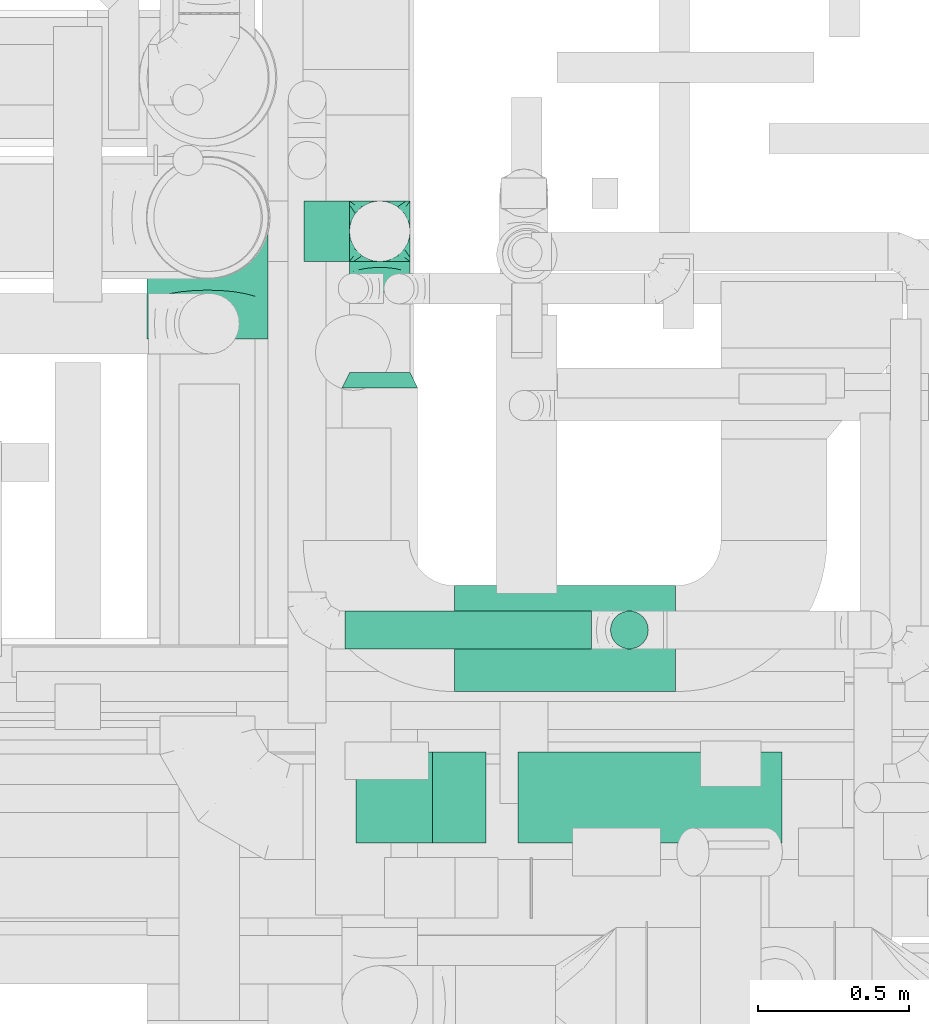
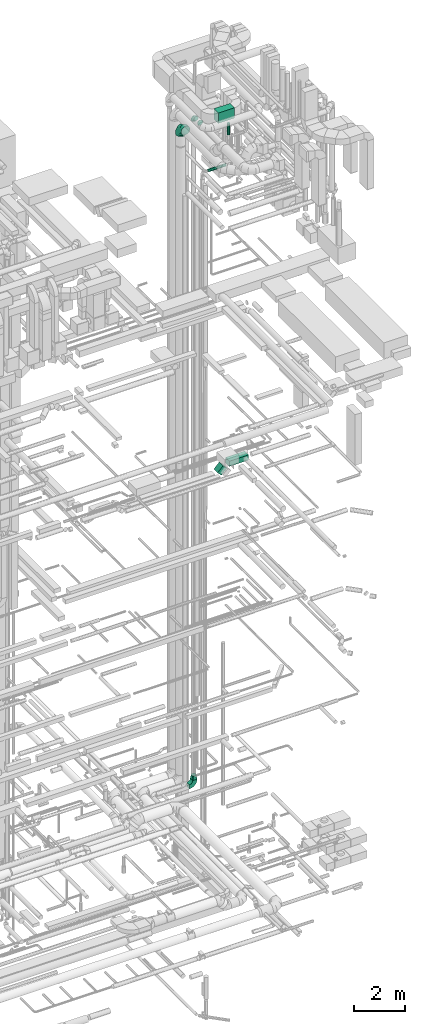
# One storey, part 261 of 337: 5 flow fittings, 5 flow segments.
"""IFC2X3 building model written with IfcOpenShell, lengths in millimetres."""

from ifc_helpers import new_model, entity, si_unit, converted_unit, derived_unit, direction, frame, frame_2d, origin, origin_2d_with_axis, place, context, subcontext, project, spatial, polyline, circle_curve, parameter, trimmed, segment, composite_curve, rectangle, circle, outline, extrude, faceted_brep, source, transform, mapped, material, type_object, type_shapes, element, save


model = new_model("IFC2X3")

# Units and contexts
model_context = context("Model", 3, precision=0.01, world=origin(), true_north=direction((6.12303176911189e-17, 1.0)))
body_context = subcontext(model_context, "Body", "Model", "MODEL_VIEW")
ifc_project = project(units=[si_unit("LENGTHUNIT", "METRE", prefix="MILLI"), si_unit("AREAUNIT", "SQUARE_METRE"), si_unit("VOLUMEUNIT", "CUBIC_METRE"), converted_unit("PLANEANGLEUNIT", "DEGREE", entity("IfcRatioMeasure", 0.0174532925199433), si_unit("PLANEANGLEUNIT", "RADIAN"), dimensions=[0, 0, 0, 0, 0, 0, 0]), si_unit("MASSUNIT", "GRAM", prefix="KILO"), derived_unit("MASSDENSITYUNIT", [(si_unit("MASSUNIT", "GRAM", prefix="KILO"), 1), (si_unit("LENGTHUNIT", "METRE"), -3)]), derived_unit("MOMENTOFINERTIAUNIT", [(si_unit("LENGTHUNIT", "METRE"), 4)]), si_unit("TIMEUNIT", "SECOND"), si_unit("FREQUENCYUNIT", "HERTZ"), si_unit("THERMODYNAMICTEMPERATUREUNIT", "DEGREE_CELSIUS"), derived_unit("THERMALTRANSMITTANCEUNIT", [(si_unit("MASSUNIT", "GRAM", prefix="KILO"), 1), (si_unit("THERMODYNAMICTEMPERATUREUNIT", "KELVIN"), -1), (si_unit("TIMEUNIT", "SECOND"), -3)]), derived_unit("VOLUMETRICFLOWRATEUNIT", [(si_unit("LENGTHUNIT", "METRE"), 3), (si_unit("TIMEUNIT", "SECOND"), -1)]), derived_unit("MASSFLOWRATEUNIT", [(si_unit("MASSUNIT", "GRAM", prefix="KILO"), 1), (si_unit("TIMEUNIT", "SECOND"), -1)]), derived_unit("ROTATIONALFREQUENCYUNIT", [(si_unit("TIMEUNIT", "SECOND"), -1)]), si_unit("ELECTRICCURRENTUNIT", "AMPERE"), si_unit("ELECTRICVOLTAGEUNIT", "VOLT"), si_unit("POWERUNIT", "WATT"), si_unit("FORCEUNIT", "NEWTON", prefix="KILO"), si_unit("ILLUMINANCEUNIT", "LUX"), si_unit("LUMINOUSFLUXUNIT", "LUMEN"), si_unit("LUMINOUSINTENSITYUNIT", "CANDELA"), derived_unit("USERDEFINED", [(si_unit("MASSUNIT", "GRAM", prefix="KILO"), -1), (si_unit("LENGTHUNIT", "METRE"), -2), (si_unit("TIMEUNIT", "SECOND"), 3), (si_unit("LUMINOUSFLUXUNIT", "LUMEN"), 1)]), derived_unit("LINEARVELOCITYUNIT", [(si_unit("LENGTHUNIT", "METRE"), 1), (si_unit("TIMEUNIT", "SECOND"), -1)]), si_unit("PRESSUREUNIT", "PASCAL"), derived_unit("USERDEFINED", [(si_unit("LENGTHUNIT", "METRE"), -2), (si_unit("MASSUNIT", "GRAM", prefix="KILO"), 1), (si_unit("TIMEUNIT", "SECOND"), -2)]), derived_unit("LINEARFORCEUNIT", [(si_unit("MASSUNIT", "GRAM", prefix="KILO"), 1), (si_unit("LENGTHUNIT", "METRE"), 1), (si_unit("TIMEUNIT", "SECOND"), -2), (si_unit("LENGTHUNIT", "METRE"), -1)]), derived_unit("PLANARFORCEUNIT", [(si_unit("MASSUNIT", "GRAM", prefix="KILO"), 1), (si_unit("LENGTHUNIT", "METRE"), 1), (si_unit("TIMEUNIT", "SECOND"), -2), (si_unit("LENGTHUNIT", "METRE"), -2)])], contexts=[model_context])

# Site, building, storey
site_placement = place(None, origin())
site = spatial("IfcSite", under=ifc_project, at=site_placement, CompositionType="ELEMENT")
building_placement = place(site_placement, origin())
building = spatial("IfcBuilding", under=site, at=building_placement, CompositionType="ELEMENT")
storey_placement = place(building_placement, origin())
storey = spatial("IfcBuildingStorey", under=building, at=storey_placement, CompositionType="ELEMENT", Elevation=0.0)

# Flow segments
duct_segment_type_1 = type_object("IfcDuctSegmentType", PredefinedType="NOTDEFINED")
flow_segment_1_placement = place(storey_placement, frame((68048.64, 9724.07, 18727.16)))
element("IfcFlowSegment", 1, at=flow_segment_1_placement, inside=storey, type_object=duct_segment_type_1, context=body_context, shape_type="SweptSolid", body=[
    extrude(rectangle(XDim=249.999999999991, YDim=300.0, at=origin_2d_with_axis()), frame((88.39, 150.0, 88.39), z_axis=(0.707106781186426, 0.0, 0.707106781186669), x_axis=(-0.707106781186669, 0.0, 0.707106781186426)), (0.0, 0.0, 1.0), 359.08116907954),
])
flow_segment_2_placement = place(storey_placement, frame((68585.39, 9724.07, 19025.0)))
element("IfcFlowSegment", 2, at=flow_segment_2_placement, inside=storey, type_object=duct_segment_type_1, context=body_context, shape_type="SweptSolid", body=[
    extrude(rectangle(XDim=871.091270347514, YDim=299.999999999999, at=origin_2d_with_axis()), frame((435.55, 150.0, 0.0), z_axis=(0.0, 0.0, 1.0), x_axis=(-1.0, 0.0, 0.0)), (0.0, 0.0, 1.0), 249.999999999999),
])
flow_segment_3_placement = place(storey_placement, frame((68374.87, 10223.58, 35280.0)))
element("IfcFlowSegment", 3, at=flow_segment_3_placement, inside=storey, type_object=duct_segment_type_1, context=body_context, shape_type="SweptSolid", body=[
    extrude(rectangle(XDim=730.500803225467, YDim=350.000000000001, at=origin_2d_with_axis()), frame((365.25, 175.0, 0.0), z_axis=(0.0, 0.0, 1.0), x_axis=(-1.0, 0.0, 0.0)), (0.0, 0.0, 1.0), 499.999999999999),
])
duct_segment_type_2 = type_object("IfcDuctSegmentType", PredefinedType="NOTDEFINED")
flow_segment_4_placement = place(storey_placement, frame((68888.36, 10363.17, 34432.5)))
element("IfcFlowSegment", 4, at=flow_segment_4_placement, inside=storey, type_object=duct_segment_type_2, context=body_context, shape_type="SweptSolid", body=[
    extrude(circle(Radius=62.5, at=origin_2d_with_axis()), frame((64.1, 64.1, 0.0)), (0.0, 0.0, 1.0), 542.499999999998),
])
flow_segment_5_placement = place(storey_placement, frame((68013.0, 10363.17, 32950.9)))
element("IfcFlowSegment", 5, at=flow_segment_5_placement, inside=storey, type_object=duct_segment_type_2, context=body_context, shape_type="SweptSolid", body=[
    extrude(circle(Radius=62.5, at=origin_2d_with_axis()), frame((0.0, 64.1, 64.1), z_axis=(1.0, 0.0, 0.0), x_axis=(0.0, 1.0, 0.0)), (0.0, 0.0, 1.0), 814.453755383621),
])

# Flow fittings
ifc_material = material()
duct_fitting_type_1 = type_object("IfcDuctFittingType", PredefinedType="NOTDEFINED", material=ifc_material)
shared_shape_1 = source(origin(), body_context, "Body", "Brep", [
    faceted_brep([(-200.0, 0.0, -100.0), (-200.0, -25.88, -96.59), (-200.0, -50.0, -86.6), (-200.0, -70.71, -70.71), (-200.0, -86.6, -50.0), (-200.0, -96.59, -25.88), (-200.0, -100.0, 0.0), (-200.0, -96.59, 25.88), (-200.0, -86.6, 50.0), (-200.0, -70.71, 70.71), (-200.0, -50.0, 86.6), (-200.0, -25.88, 96.59), (-200.0, 0.0, 100.0), (-200.0, 25.88, 96.59), (-200.0, 50.0, 86.6), (-200.0, 70.71, 70.71), (-200.0, 86.6, 50.0), (-200.0, 96.59, 25.88), (-200.0, 100.0, 0.0), (-200.0, 96.59, -25.88), (-200.0, 86.6, -50.0), (-200.0, 70.71, -70.71), (-200.0, 50.0, -86.6), (-200.0, 25.88, -96.59), (-153.35, 25.88, 96.59), (-159.81, 50.0, 86.6), (-146.41, 0.0, 100.0), (-165.36, 70.71, 70.71), (-172.29, 96.59, 25.88), (-173.21, 100.0, 0.0), (-169.62, 86.6, 50.0), (-169.62, 86.6, -50.0), (-165.36, 70.71, -70.71), (-172.29, 96.59, -25.88), (-153.35, 25.88, -96.59), (-146.41, 0.0, -100.0), (-159.81, 50.0, -86.6), (-139.48, -25.88, -96.59), (-133.01, -50.0, -86.6), (-127.46, -70.71, -70.71), (-123.21, -86.6, -50.0), (-120.53, -96.59, -25.88), (-119.62, -100.0, 0.0), (-120.53, -96.59, 25.88), (-123.21, -86.6, 50.0), (-127.46, -70.71, 70.71), (-133.01, -50.0, 86.6), (-139.48, -25.88, 96.59), (-72.54, 72.54, 96.59), (-90.19, 90.19, 86.6), (-53.59, 53.59, 100.0), (-105.35, 105.35, 70.71), (-116.99, 116.99, 50.0), (-124.3, 124.3, 25.88), (-126.79, 126.79, 0.0), (-124.3, 124.3, -25.88), (-116.99, 116.99, -50.0), (-105.35, 105.35, -70.71), (-72.54, 72.54, -96.59), (-53.59, 53.59, -100.0), (-90.19, 90.19, -86.6), (-34.64, 34.64, -96.59), (-16.99, 16.99, -86.6), (-1.83, 1.83, -70.71), (9.81, -9.81, -50.0), (17.12, -17.12, -25.88), (19.62, -19.62, 0.0), (17.12, -17.12, 25.88), (9.81, -9.81, 50.0), (-1.83, 1.83, 70.71), (-16.99, 16.99, 86.6), (-34.64, 34.64, 96.59), (-25.88, 153.35, 96.59), (-50.0, 159.81, 86.6), (0.0, 146.41, 100.0), (-70.71, 165.36, 70.71), (-86.6, 169.62, 50.0), (-96.59, 172.29, 25.88), (-100.0, 173.21, 0.0), (-96.59, 172.29, -25.88), (-86.6, 169.62, -50.0), (-70.71, 165.36, -70.71), (-25.88, 153.35, -96.59), (0.0, 146.41, -100.0), (-50.0, 159.81, -86.6), (25.88, 139.48, -96.59), (50.0, 133.01, -86.6), (70.71, 127.46, -70.71), (86.6, 123.21, -50.0), (96.59, 120.53, -25.88), (100.0, 119.62, 0.0), (96.59, 120.53, 25.88), (86.6, 123.21, 50.0), (70.71, 127.46, 70.71), (50.0, 133.01, 86.6), (25.88, 139.48, 96.59), (-25.88, 200.0, -96.59), (-50.0, 200.0, -86.6), (-70.71, 200.0, -70.71), (-86.6, 200.0, -50.0), (-96.59, 200.0, -25.88), (-100.0, 200.0, 0.0), (-96.59, 200.0, 25.88), (-86.6, 200.0, 50.0), (-70.71, 200.0, 70.71), (-50.0, 200.0, 86.6), (-25.88, 200.0, 96.59), (0.0, 200.0, 100.0), (25.88, 200.0, 96.59), (50.0, 200.0, 86.6), (70.71, 200.0, 70.71), (86.6, 200.0, 50.0), (96.59, 200.0, 25.88), (100.0, 200.0, 0.0), (96.59, 200.0, -25.88), (86.6, 200.0, -50.0), (70.71, 200.0, -70.71), (50.0, 200.0, -86.6), (25.88, 200.0, -96.59), (0.0, 200.0, -100.0)], [[[0, 1, 2, 3, 4, 5, 6, 7, 8, 9, 10, 11, 12, 13, 14, 15, 16, 17, 18, 19, 20, 21, 22, 23]], [[24, 25, 14, 13]], [[26, 24, 13, 12]], [[14, 25, 27, 15]], [[28, 29, 18, 17]], [[30, 28, 17, 16]], [[15, 27, 30, 16]], [[20, 31, 32, 21]], [[33, 31, 20, 19]], [[18, 29, 33, 19]], [[34, 35, 0, 23]], [[36, 34, 23, 22]], [[32, 36, 22, 21]], [[1, 0, 35, 37]], [[2, 1, 37, 38]], [[38, 39, 3, 2]], [[5, 4, 40, 41]], [[6, 5, 41, 42]], [[39, 40, 4, 3]], [[6, 42, 43, 7]], [[7, 43, 44, 8]], [[8, 44, 45, 9]], [[9, 45, 46, 10]], [[10, 46, 47, 11]], [[26, 12, 11, 47]], [[48, 49, 25, 24]], [[50, 48, 24, 26]], [[27, 25, 49, 51]], [[52, 53, 28, 30]], [[51, 52, 30, 27]], [[29, 28, 53, 54]], [[55, 56, 31, 33]], [[54, 55, 33, 29]], [[32, 31, 56, 57]], [[58, 59, 35, 34]], [[60, 58, 34, 36]], [[57, 60, 36, 32]], [[37, 35, 59, 61]], [[38, 37, 61, 62]], [[39, 38, 62, 63]], [[41, 40, 64, 65]], [[42, 41, 65, 66]], [[63, 64, 40, 39]], [[43, 42, 66, 67]], [[44, 43, 67, 68]], [[68, 69, 45, 44]], [[46, 45, 69, 70]], [[47, 46, 70, 71]], [[26, 47, 71, 50]], [[72, 73, 49, 48]], [[74, 72, 48, 50]], [[51, 49, 73, 75]], [[76, 77, 53, 52]], [[75, 76, 52, 51]], [[54, 53, 77, 78]], [[79, 80, 56, 55]], [[78, 79, 55, 54]], [[57, 56, 80, 81]], [[82, 83, 59, 58]], [[84, 82, 58, 60]], [[81, 84, 60, 57]], [[61, 59, 83, 85]], [[62, 61, 85, 86]], [[63, 62, 86, 87]], [[65, 64, 88, 89]], [[66, 65, 89, 90]], [[87, 88, 64, 63]], [[67, 66, 90, 91]], [[68, 67, 91, 92]], [[92, 93, 69, 68]], [[70, 69, 93, 94]], [[71, 70, 94, 95]], [[50, 71, 95, 74]], [[96, 97, 98, 99, 100, 101, 102, 103, 104, 105, 106, 107, 108, 109, 110, 111, 112, 113, 114, 115, 116, 117, 118, 119]], [[72, 74, 107, 106]], [[73, 72, 106, 105]], [[75, 73, 105, 104]], [[102, 101, 78, 77]], [[103, 102, 77, 76]], [[75, 104, 103, 76]], [[78, 101, 100, 79]], [[79, 100, 99, 80]], [[80, 99, 98, 81]], [[84, 97, 96, 82]], [[82, 96, 119, 83]], [[84, 81, 98, 97]], [[118, 117, 86, 85]], [[119, 118, 85, 83]], [[116, 87, 86, 117]], [[88, 115, 114, 89]], [[89, 114, 113, 90]], [[115, 88, 87, 116]], [[91, 90, 113, 112]], [[92, 91, 112, 111]], [[111, 110, 93, 92]], [[95, 94, 109, 108]], [[74, 95, 108, 107]], [[110, 109, 94, 93]]]),
])
type_shapes(duct_fitting_type_1, [shared_shape_1])
flow_fitting_1_placement = place(storey_placement, frame((68128.1, 11744.28, 34800.0), z_axis=(-1.0, 0.0, 0.0), x_axis=(0.0, 1.0, 0.0)))
element("IfcFlowFitting", 6, at=flow_fitting_1_placement, inside=storey, type_object=duct_fitting_type_1, material=ifc_material, context=body_context, shape_type="MappedRepresentation", body=[
    mapped(shared_shape_1, transform((0.0, 0.0, 0.0), scale=1.0)),
])
duct_fitting_type_2 = type_object("IfcDuctFittingType", PredefinedType="NOTDEFINED", material=ifc_material)
shared_shape_2 = source(origin(), body_context, "Body", "Brep", [
    faceted_brep([(-400.0, 0.0, -200.0), (-400.0, -44.5, -194.99), (-400.0, -86.78, -180.19), (-400.0, -124.7, -156.37), (-400.0, -156.37, -124.7), (-400.0, -180.19, -86.78), (-400.0, -194.99, -44.5), (-400.0, -200.0, 0.0), (-400.0, -194.99, 44.5), (-400.0, -180.19, 86.78), (-400.0, -156.37, 124.7), (-400.0, -124.7, 156.37), (-400.0, -86.78, 180.19), (-400.0, -44.5, 194.99), (-400.0, 0.0, 200.0), (-400.0, 44.5, 194.99), (-400.0, 86.78, 180.19), (-400.0, 124.7, 156.37), (-400.0, 156.37, 124.7), (-400.0, 180.19, 86.78), (-400.0, 194.99, 44.5), (-400.0, 200.0, 0.0), (-400.0, 194.99, -44.5), (-400.0, 180.19, -86.78), (-400.0, 156.37, -124.7), (-400.0, 124.7, -156.37), (-400.0, 86.78, -180.19), (-400.0, 44.5, -194.99), (-292.82, 0.0, 200.0), (-304.75, 44.5, 194.99), (-316.07, 86.78, 180.19), (-326.23, 124.7, 156.37), (-334.72, 156.37, 124.7), (-341.1, 180.19, 86.78), (-345.07, 194.99, 44.5), (-346.41, 200.0, 0.0), (-345.07, 194.99, -44.5), (-341.1, 180.19, -86.78), (-334.72, 156.37, -124.7), (-326.23, 124.7, -156.37), (-316.07, 86.78, -180.19), (-304.75, 44.5, -194.99), (-292.82, 0.0, -200.0), (-280.9, -44.5, -194.99), (-269.57, -86.78, -180.19), (-259.41, -124.7, -156.37), (-250.92, -156.37, -124.7), (-244.54, -180.19, -86.78), (-240.57, -194.99, -44.5), (-239.23, -200.0, 0.0), (-240.57, -194.99, 44.5), (-244.54, -180.19, 86.78), (-250.92, -156.37, 124.7), (-259.41, -124.7, 156.37), (-269.57, -86.78, 180.19), (-280.9, -44.5, 194.99), (-107.18, 107.18, 200.0), (-139.76, 139.76, 194.99), (-170.7, 170.7, 180.19), (-198.46, 198.46, 156.37), (-221.65, 221.65, 124.7), (-239.09, 239.09, 86.78), (-249.92, 249.92, 44.5), (-253.59, 253.59, 0.0), (-249.92, 249.92, -44.5), (-239.09, 239.09, -86.78), (-221.65, 221.65, -124.7), (-198.46, 198.46, -156.37), (-170.7, 170.7, -180.19), (-139.76, 139.76, -194.99), (-107.18, 107.18, -200.0), (-74.6, 74.6, -194.99), (-43.65, 43.65, -180.19), (-15.89, 15.89, -156.37), (7.29, -7.29, -124.7), (24.73, -24.73, -86.78), (35.56, -35.56, -44.5), (39.23, -39.23, 0.0), (35.56, -35.56, 44.5), (24.73, -24.73, 86.78), (7.29, -7.29, 124.7), (-15.89, 15.89, 156.37), (-43.65, 43.65, 180.19), (-74.6, 74.6, 194.99), (0.0, 292.82, 200.0), (-44.5, 304.75, 194.99), (-86.78, 316.07, 180.19), (-124.7, 326.23, 156.37), (-156.37, 334.72, 124.7), (-180.19, 341.1, 86.78), (-194.99, 345.07, 44.5), (-200.0, 346.41, 0.0), (-194.99, 345.07, -44.5), (-180.19, 341.1, -86.78), (-156.37, 334.72, -124.7), (-124.7, 326.23, -156.37), (-86.78, 316.07, -180.19), (-44.5, 304.75, -194.99), (0.0, 292.82, -200.0), (44.5, 280.9, -194.99), (86.78, 269.57, -180.19), (124.7, 259.41, -156.37), (156.37, 250.92, -124.7), (180.19, 244.54, -86.78), (194.99, 240.57, -44.5), (200.0, 239.23, 0.0), (194.99, 240.57, 44.5), (180.19, 244.54, 86.78), (156.37, 250.92, 124.7), (124.7, 259.41, 156.37), (86.78, 269.57, 180.19), (44.5, 280.9, 194.99), (-44.5, 400.0, -194.99), (-86.78, 400.0, -180.19), (-124.7, 400.0, -156.37), (-156.37, 400.0, -124.7), (-180.19, 400.0, -86.78), (-194.99, 400.0, -44.5), (-200.0, 400.0, 0.0), (-194.99, 400.0, 44.5), (-180.19, 400.0, 86.78), (-156.37, 400.0, 124.7), (-124.7, 400.0, 156.37), (-86.78, 400.0, 180.19), (-44.5, 400.0, 194.99), (0.0, 400.0, 200.0), (44.5, 400.0, 194.99), (86.78, 400.0, 180.19), (124.7, 400.0, 156.37), (156.37, 400.0, 124.7), (180.19, 400.0, 86.78), (194.99, 400.0, 44.5), (200.0, 400.0, 0.0), (194.99, 400.0, -44.5), (180.19, 400.0, -86.78), (156.37, 400.0, -124.7), (124.7, 400.0, -156.37), (86.78, 400.0, -180.19), (44.5, 400.0, -194.99), (0.0, 400.0, -200.0)], [[[0, 1, 2, 3, 4, 5, 6, 7, 8, 9, 10, 11, 12, 13, 14, 15, 16, 17, 18, 19, 20, 21, 22, 23, 24, 25, 26, 27]], [[28, 29, 15, 14]], [[30, 31, 17, 16]], [[29, 30, 16, 15]], [[31, 32, 18, 17]], [[32, 33, 19, 18]], [[34, 35, 21, 20]], [[33, 34, 20, 19]], [[35, 36, 22, 21]], [[37, 38, 24, 23]], [[36, 37, 23, 22]], [[38, 39, 25, 24]], [[39, 40, 26, 25]], [[41, 42, 0, 27]], [[40, 41, 27, 26]], [[1, 0, 42, 43]], [[43, 44, 2, 1]], [[45, 3, 2, 44]], [[45, 46, 4, 3]], [[5, 4, 46, 47]], [[47, 48, 6, 5]], [[49, 7, 6, 48]], [[7, 49, 50, 8]], [[8, 50, 51, 9]], [[9, 51, 52, 10]], [[52, 53, 11, 10]], [[11, 53, 54, 12]], [[12, 54, 55, 13]], [[13, 55, 28, 14]], [[56, 57, 29, 28]], [[58, 59, 31, 30]], [[57, 58, 30, 29]], [[59, 60, 32, 31]], [[60, 61, 33, 32]], [[62, 63, 35, 34]], [[61, 62, 34, 33]], [[63, 64, 36, 35]], [[65, 66, 38, 37]], [[64, 65, 37, 36]], [[66, 67, 39, 38]], [[67, 68, 40, 39]], [[69, 70, 42, 41]], [[68, 69, 41, 40]], [[43, 42, 70, 71]], [[71, 72, 44, 43]], [[73, 45, 44, 72]], [[73, 74, 46, 45]], [[47, 46, 74, 75]], [[75, 76, 48, 47]], [[77, 49, 48, 76]], [[50, 49, 77, 78]], [[51, 50, 78, 79]], [[52, 51, 79, 80]], [[80, 81, 53, 52]], [[54, 53, 81, 82]], [[55, 54, 82, 83]], [[28, 55, 83, 56]], [[84, 85, 57, 56]], [[86, 87, 59, 58]], [[85, 86, 58, 57]], [[87, 88, 60, 59]], [[88, 89, 61, 60]], [[90, 91, 63, 62]], [[89, 90, 62, 61]], [[91, 92, 64, 63]], [[93, 94, 66, 65]], [[92, 93, 65, 64]], [[94, 95, 67, 66]], [[95, 96, 68, 67]], [[97, 98, 70, 69]], [[96, 97, 69, 68]], [[71, 70, 98, 99]], [[99, 100, 72, 71]], [[101, 73, 72, 100]], [[101, 102, 74, 73]], [[75, 74, 102, 103]], [[103, 104, 76, 75]], [[105, 77, 76, 104]], [[78, 77, 105, 106]], [[79, 78, 106, 107]], [[80, 79, 107, 108]], [[108, 109, 81, 80]], [[82, 81, 109, 110]], [[83, 82, 110, 111]], [[56, 83, 111, 84]], [[112, 113, 114, 115, 116, 117, 118, 119, 120, 121, 122, 123, 124, 125, 126, 127, 128, 129, 130, 131, 132, 133, 134, 135, 136, 137, 138, 139]], [[85, 84, 125, 124]], [[86, 85, 124, 123]], [[87, 86, 123, 122]], [[122, 121, 88, 87]], [[89, 88, 121, 120]], [[90, 89, 120, 119]], [[91, 90, 119, 118]], [[91, 118, 117, 92]], [[92, 117, 116, 93]], [[93, 116, 115, 94]], [[115, 114, 95, 94]], [[95, 114, 113, 96]], [[96, 113, 112, 97]], [[97, 112, 139, 98]], [[98, 139, 138, 99]], [[99, 138, 137, 100]], [[100, 137, 136, 101]], [[136, 135, 102, 101]], [[102, 135, 134, 103]], [[103, 134, 133, 104]], [[104, 133, 132, 105]], [[106, 105, 132, 131]], [[107, 106, 131, 130]], [[108, 107, 130, 129]], [[129, 128, 109, 108]], [[110, 109, 128, 127]], [[111, 110, 127, 126]], [[84, 111, 126, 125]]]),
])
type_shapes(duct_fitting_type_2, [shared_shape_2])
flow_fitting_2_placement = place(storey_placement, frame((67559.05, 11789.15, 34520.0), z_axis=(-1.0, 0.0, 0.0), x_axis=(0.0, 1.0, 0.0)))
element("IfcFlowFitting", 7, at=flow_fitting_2_placement, inside=storey, type_object=duct_fitting_type_2, material=ifc_material, context=body_context, shape_type="MappedRepresentation", body=[
    mapped(shared_shape_2, transform((0.0, 0.0, 0.0), scale=1.0)),
])
duct_fitting_type_3 = type_object("IfcDuctFittingType", PredefinedType="NOTDEFINED", material=ifc_material)
shared_shape_3 = source(origin(), body_context, "Body", "Brep", [
    faceted_brep([(200.0, 30.9, 95.11), (200.0, 19.08, 96.98), (200.0, 9.54, 98.49), (200.0, 4.77, 99.24), (200.0, 0.0, 100.0), (200.0, -4.77, 99.24), (200.0, -9.54, 98.49), (200.0, -19.08, 96.98), (200.0, -30.9, 95.11), (200.0, -44.84, 88.0), (200.0, -58.78, 80.9), (200.0, -69.84, 69.84), (200.0, -80.9, 58.78), (200.0, -88.0, 44.84), (200.0, -95.11, 30.9), (200.0, -96.98, 19.08), (200.0, -98.49, 9.54), (200.0, -99.24, 4.77), (200.0, -100.0, 0.0), (200.0, -99.24, -4.77), (200.0, -98.49, -9.54), (200.0, -96.98, -19.08), (200.0, -95.11, -30.9), (200.0, -88.0, -44.84), (200.0, -80.9, -58.78), (200.0, -69.84, -69.84), (200.0, -58.78, -80.9), (200.0, -44.84, -88.0), (200.0, -30.9, -95.11), (200.0, -19.08, -96.98), (200.0, -9.54, -98.49), (200.0, -4.77, -99.24), (200.0, 0.0, -100.0), (200.0, 4.77, -99.24), (200.0, 9.54, -98.49), (200.0, 19.08, -96.98), (200.0, 30.9, -95.11), (200.0, 44.84, -88.0), (200.0, 58.78, -80.9), (200.0, 69.84, -69.84), (200.0, 80.9, -58.78), (200.0, 88.0, -44.84), (200.0, 95.11, -30.9), (200.0, 96.98, -19.08), (200.0, 98.49, -9.54), (200.0, 99.24, -4.77), (200.0, 100.0, 0.0), (200.0, 99.24, 4.77), (200.0, 98.49, 9.54), (200.0, 96.98, 19.08), (200.0, 95.11, 30.9), (200.0, 88.0, 44.84), (200.0, 80.9, 58.78), (200.0, 69.84, 69.84), (200.0, 58.78, 80.9), (200.0, 44.84, 88.0), (0.0, -100.0, 100.0), (0.0, 100.0, 100.0), (0.0, 100.0, -100.0), (0.0, -100.0, -100.0), (104.11, -47.94, 100.0), (100.0, -83.15, 87.43), (26.03, -86.99, 100.0), (78.09, -60.96, 100.0), (52.06, -73.97, 100.0), (188.01, -5.99, 100.0), (176.03, -11.99, 100.0), (152.06, -23.97, 100.0), (128.09, -35.96, 100.0), (52.06, -100.0, 73.97), (78.09, -100.0, 60.96), (104.11, -100.0, 47.94), (128.09, -100.0, 35.96), (152.06, -100.0, 23.97), (176.03, -100.0, 11.99), (188.01, -100.0, 5.99), (26.03, -100.0, 86.99), (26.03, -100.0, -86.99), (52.06, -100.0, -73.97), (78.09, -100.0, -60.96), (104.11, -100.0, -47.94), (128.09, -100.0, -35.96), (152.06, -100.0, -23.97), (176.03, -100.0, -11.99), (188.01, -100.0, -5.99), (100.0, -87.43, -83.15), (52.06, -73.97, -100.0), (78.09, -60.96, -100.0), (104.11, -47.94, -100.0), (128.09, -35.96, -100.0), (152.06, -23.97, -100.0), (176.03, -11.99, -100.0), (188.01, -5.99, -100.0), (26.03, -86.99, -100.0), (26.03, 86.99, -100.0), (52.06, 73.97, -100.0), (78.09, 60.96, -100.0), (104.11, 47.94, -100.0), (128.09, 35.96, -100.0), (152.06, 23.97, -100.0), (176.03, 11.99, -100.0), (188.01, 5.99, -100.0), (100.0, 83.15, -87.43), (52.06, 100.0, -73.97), (78.09, 100.0, -60.96), (104.11, 100.0, -47.94), (128.09, 100.0, -35.96), (152.06, 100.0, -23.97), (176.03, 100.0, -11.99), (188.01, 100.0, -5.99), (26.03, 100.0, -86.99), (26.03, 100.0, 86.99), (52.06, 100.0, 73.97), (78.09, 100.0, 60.96), (104.11, 100.0, 47.94), (128.09, 100.0, 35.96), (152.06, 100.0, 23.97), (176.03, 100.0, 11.99), (188.01, 100.0, 5.99), (100.0, 87.43, 83.15), (52.06, 73.97, 100.0), (78.09, 60.96, 100.0), (104.11, 47.94, 100.0), (128.09, 35.96, 100.0), (152.06, 23.97, 100.0), (176.03, 11.99, 100.0), (188.01, 5.99, 100.0), (26.03, 86.99, 100.0)], [[[0, 1, 2, 3, 4, 5, 6, 7, 8, 9, 10, 11, 12, 13, 14, 15, 16, 17, 18, 19, 20, 21, 22, 23, 24, 25, 26, 27, 28, 29, 30, 31, 32, 33, 34, 35, 36, 37, 38, 39, 40, 41, 42, 43, 44, 45, 46, 47, 48, 49, 50, 51, 52, 53, 54, 55]], [[56, 57, 58, 59]], [[60, 9, 8]], [[56, 61, 62]], [[9, 60, 63, 64]], [[65, 66, 67, 68, 60, 8, 7, 6, 5, 4]], [[62, 61, 10]], [[13, 69, 70, 71]], [[64, 10, 9]], [[14, 71, 72, 73, 74, 75, 18, 17, 16, 15]], [[12, 76, 69]], [[71, 14, 13]], [[61, 76, 11]], [[10, 64, 62]], [[76, 12, 11]], [[10, 61, 11]], [[61, 56, 76]], [[69, 13, 12]], [[75, 74, 73, 72, 71, 70, 69, 76, 56, 59, 77, 78, 79, 80, 81, 82, 83, 84, 18]], [[80, 23, 22]], [[59, 85, 77]], [[23, 80, 79, 78]], [[84, 83, 82, 81, 80, 22, 21, 20, 19, 18]], [[77, 85, 24]], [[27, 86, 87, 88]], [[78, 24, 23]], [[28, 88, 89, 90, 91, 92, 32, 31, 30, 29]], [[26, 93, 86]], [[88, 28, 27]], [[85, 93, 25]], [[24, 78, 77]], [[93, 26, 25]], [[24, 85, 25]], [[85, 59, 93]], [[86, 27, 26]], [[92, 91, 90, 89, 88, 87, 86, 93, 59, 58, 94, 95, 96, 97, 98, 99, 100, 101, 32]], [[97, 37, 36]], [[58, 102, 94]], [[37, 97, 96, 95]], [[101, 100, 99, 98, 97, 36, 35, 34, 33, 32]], [[94, 102, 38]], [[41, 103, 104, 105]], [[95, 38, 37]], [[42, 105, 106, 107, 108, 109, 46, 45, 44, 43]], [[40, 110, 103]], [[105, 42, 41]], [[102, 110, 39]], [[38, 95, 94]], [[110, 40, 39]], [[38, 102, 39]], [[102, 58, 110]], [[103, 41, 40]], [[58, 57, 111, 112, 113, 114, 115, 116, 117, 118, 46, 109, 108, 107, 106, 105, 104, 103, 110]], [[114, 51, 50]], [[57, 119, 111]], [[51, 114, 113, 112]], [[118, 117, 116, 115, 114, 50, 49, 48, 47, 46]], [[111, 119, 52]], [[55, 120, 121, 122]], [[112, 52, 51]], [[0, 122, 123, 124, 125, 126, 4, 3, 2, 1]], [[54, 127, 120]], [[122, 0, 55]], [[119, 127, 53]], [[52, 112, 111]], [[127, 54, 53]], [[52, 119, 53]], [[119, 57, 127]], [[120, 55, 54]], [[57, 56, 62, 64, 63, 60, 68, 67, 66, 65, 4, 126, 125, 124, 123, 122, 121, 120, 127]]]),
])
type_shapes(duct_fitting_type_3, [shared_shape_3])
flow_fitting_3_placement = place(storey_placement, frame((68128.1, 11744.28, 2950.0), z_axis=(-1.0, 0.0, 0.0), x_axis=(0.0, 0.0, 1.0)))
element("IfcFlowFitting", 8, at=flow_fitting_3_placement, inside=storey, type_object=duct_fitting_type_3, material=ifc_material, context=body_context, shape_type="MappedRepresentation", body=[
    mapped(shared_shape_3, transform((0.0, 0.0, 0.0), scale=1.0)),
])
duct_fitting_type_4 = type_object("IfcDuctFittingType", PredefinedType="NOTDEFINED", material=ifc_material)
shared_shape_4 = source(origin(), body_context, "Body", "Brep", [
    faceted_brep([(50.0, -73.47, -101.13), (50.0, -38.63, -118.88), (50.0, 0.0, -125.0), (50.0, 38.63, -118.88), (50.0, 73.47, -101.13), (50.0, 101.13, -73.47), (50.0, 118.88, -38.63), (50.0, 125.0, 0.0), (50.0, 118.88, 38.63), (50.0, 101.13, 73.47), (50.0, 73.47, 101.13), (50.0, 38.63, 118.88), (50.0, 0.0, 125.0), (50.0, -38.63, 118.88), (50.0, -73.47, 101.13), (50.0, -101.13, 73.47), (50.0, -118.88, 38.63), (50.0, -125.0, 0.0), (50.0, -118.88, -38.63), (50.0, -101.13, -73.47), (0.0, 30.9, -95.11), (0.0, 0.0, -100.0), (0.0, -30.9, -95.11), (0.0, -58.78, -80.9), (0.0, -80.9, -58.78), (0.0, -95.11, -30.9), (0.0, -100.0, 0.0), (0.0, -95.11, 30.9), (0.0, -80.9, 58.78), (0.0, -58.78, 80.9), (0.0, -30.9, 95.11), (0.0, 0.0, 100.0), (0.0, 30.9, 95.11), (0.0, 58.78, 80.9), (0.0, 80.9, 58.78), (0.0, 95.11, 30.9), (0.0, 100.0, 0.0), (0.0, 95.11, -30.9), (0.0, 80.9, -58.78), (0.0, 58.78, -80.9)], [[[0, 1, 2, 3, 4, 5, 6, 7, 8, 9, 10, 11, 12, 13, 14, 15, 16, 17, 18, 19]], [[20, 21, 22, 23, 24, 25, 26, 27, 28, 29, 30, 31, 32, 33, 34, 35, 36, 37, 38, 39]], [[35, 34, 9, 8]], [[36, 35, 8, 7]], [[34, 33, 10, 9]], [[10, 33, 32, 11]], [[11, 32, 31, 12]], [[30, 29, 14, 13]], [[31, 30, 13, 12]], [[29, 28, 15, 14]], [[15, 28, 27, 16]], [[16, 27, 26, 17]], [[25, 24, 19, 18]], [[26, 25, 18, 17]], [[24, 23, 0, 19]], [[0, 23, 22, 1]], [[1, 22, 21, 2]], [[20, 39, 4, 3]], [[21, 20, 3, 2]], [[39, 38, 5, 4]], [[5, 38, 37, 6]], [[6, 37, 36, 7]]]),
])
type_shapes(duct_fitting_type_4, [shared_shape_4])
flow_fitting_4_placement = place(storey_placement, frame((68128.1, 11277.11, 34800.0), z_axis=(0.0, 0.0, 1.0), x_axis=(0.0, -1.0, 0.0)))
element("IfcFlowFitting", 9, at=flow_fitting_4_placement, inside=storey, type_object=duct_fitting_type_4, material=ifc_material, context=body_context, shape_type="MappedRepresentation", body=[
    mapped(shared_shape_4, transform((0.0, 0.0, 0.0), scale=1.0)),
])
duct_fitting_type_5 = type_object("IfcDuctFittingType", PredefinedType="NOTDEFINED", material=ifc_material)
shared_shape_5 = source(origin(), body_context, "Body", "SweptSolid", [
    extrude(outline(composite_curve([segment(polyline([(-225.0, -125.0), (-25.0, -125.0)]), True, "CONTINUOUS"), segment(trimmed(circle_curve(frame_2d((125.0, -125.0), x_axis=(0.0, 1.0)), 150.0), [parameter(0.0)], [parameter(90.0)], True, "PARAMETER"), False, "CONTINUOUS"), segment(polyline([(125.0, 25.0), (125.0, 225.0)]), True, "CONTINUOUS"), segment(trimmed(circle_curve(frame_2d((125.0, -125.0), x_axis=(0.0, 1.0)), 350.0), [parameter(0.0)], [parameter(90.0)], True, "PARAMETER"), True, "CONTINUOUS")], self_intersect=False)), frame((-125.0, 125.0, -100.0), z_axis=(0.0, 0.0, 1.0), x_axis=(-1.0, 0.0, 0.0)), (0.0, 0.0, 1.0), 200.0),
])
type_shapes(duct_fitting_type_5, [shared_shape_5])
flow_fitting_5_placement = place(storey_placement, frame((68128.1, 11744.28, 2700.0), z_axis=(0.0, 1.0, 0.0), x_axis=(0.0, 0.0, -1.0)))
element("IfcFlowFitting", 10, at=flow_fitting_5_placement, inside=storey, type_object=duct_fitting_type_5, material=ifc_material, context=body_context, shape_type="MappedRepresentation", body=[
    mapped(shared_shape_5, transform((0.0, 0.0, 0.0), scale=1.0)),
])

save(model, "model.ifc")
